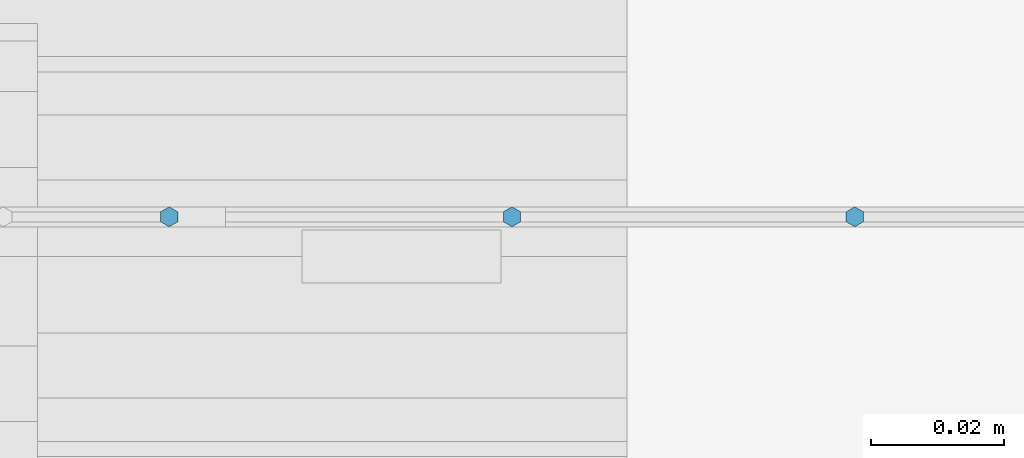
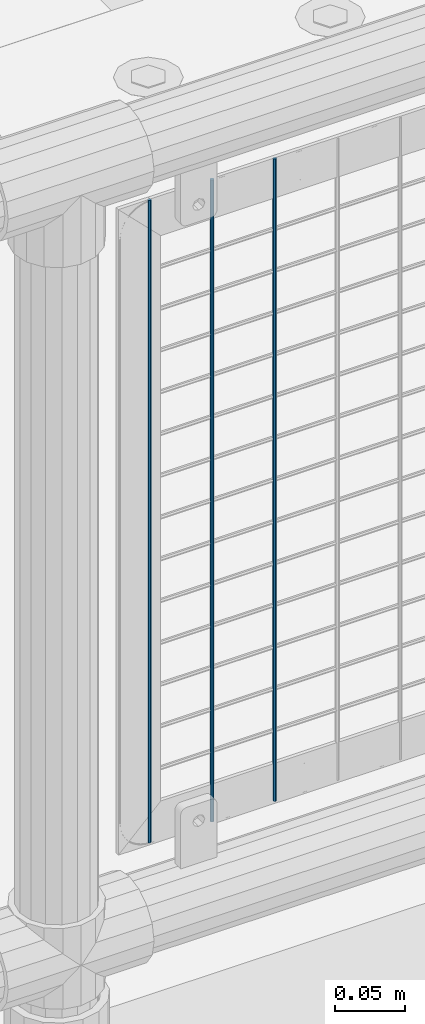
# One storey, part 74 of 193: 3 columns.
"""IFC2X3 building model written with IfcOpenShell, lengths in millimetres."""

from ifc_helpers import new_model, si_unit, frame, origin_with_axes, place, context, subcontext, project, spatial, faceted_brep, material, type_object, element, save


model = new_model("IFC2X3")

# Units and contexts
model_context = context("Model", 3, precision=1e-05, world=origin_with_axes())
body_context = subcontext(model_context, "Body", "Model", "MODEL_VIEW")
ifc_project = project(units=[si_unit("LENGTHUNIT", "METRE", prefix="MILLI"), si_unit("AREAUNIT", "SQUARE_METRE"), si_unit("VOLUMEUNIT", "CUBIC_METRE"), si_unit("MASSUNIT", "GRAM", prefix="KILO"), si_unit("TIMEUNIT", "SECOND"), si_unit("PLANEANGLEUNIT", "RADIAN"), si_unit("SOLIDANGLEUNIT", "STERADIAN"), si_unit("THERMODYNAMICTEMPERATUREUNIT", "DEGREE_CELSIUS"), si_unit("LUMINOUSINTENSITYUNIT", "LUMEN")], contexts=[model_context])

# Site, building, storey
site_placement = place(None, origin_with_axes())
site = spatial("IfcSite", under=ifc_project, at=site_placement, CompositionType="ELEMENT")
building_placement = place(site_placement, origin_with_axes())
building = spatial("IfcBuilding", under=site, at=building_placement, Name="Standard", CompositionType="ELEMENT")
storey_placement = place(building_placement, origin_with_axes())
storey = spatial("IfcBuildingStorey", under=building, at=storey_placement, Name="Undefined", CompositionType="ELEMENT", Elevation=0.0)

# Columns
ifc_material = material(Name="Misc_Undefined")
column_type = type_object("IfcColumnType", Name="D3", PredefinedType="NOTDEFINED")
for number, where, z_axis, x_axis in (
    (1, (-33355.69, 28670.5, 353.020000000001), (-1.0, 0.0, 0.0), (0.0, 0.0, 1.0)),
    (2, (-33407.345, 28670.5, 353.020000000001), (-1.0, 0.0, 0.0), (0.0, 0.0, 1.0)),
    (3, (-33459.0, 28670.5, 353.020000000001), (-1.0, 0.0, 0.0), (0.0, 0.0, 1.0)),
):
    element("IfcColumn", number, at=place(storey_placement, frame(where, z_axis=z_axis, x_axis=x_axis)), inside=storey, type_object=column_type, material=ifc_material, ObjectType="D3", context=body_context, shape_type="Brep", body=[
        faceted_brep([(0.0, -1.49999999999636, 3.63797880709171e-12), (0.0, -0.75, -1.29903810567669), (560.0, -0.75, -1.29903810567703), (560.0, -1.5, 0.0), (0.0, 0.75, -1.29903810567669), (560.0, 0.75, -1.29903810567703), (0.0, 1.50000000000364, 7.27595761418343e-12), (560.0, 1.5, 0.0), (0.0, 0.75, 1.29903810567669), (560.0, 0.75, 1.29903810567703), (0.0, -0.75, 1.29903810567669), (560.0, -0.75, 1.29903810567703)], [[[0, 1, 2, 3]], [[1, 4, 5, 2]], [[4, 6, 7, 5]], [[6, 8, 9, 7]], [[8, 10, 11, 9]], [[10, 0, 3, 11]], [[5, 7, 9, 11, 3, 2]], [[10, 8, 6, 4, 1, 0]]]),
    ])

save(model, "model.ifc")
